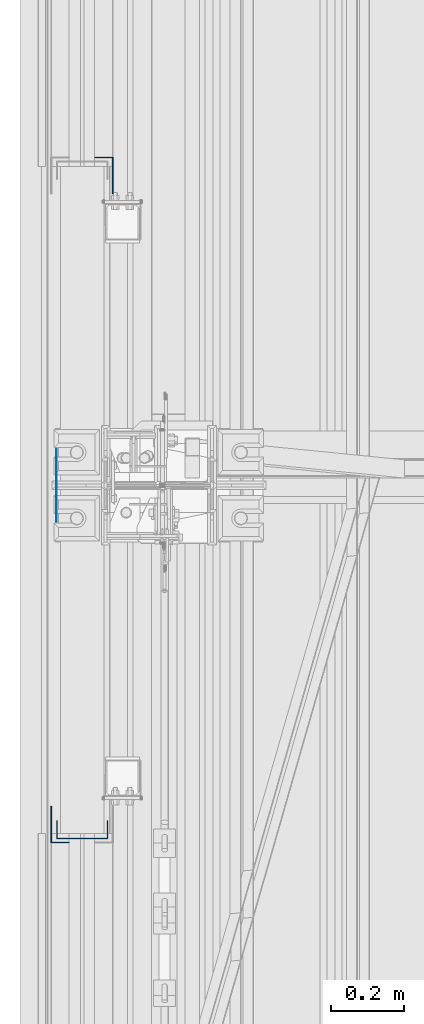
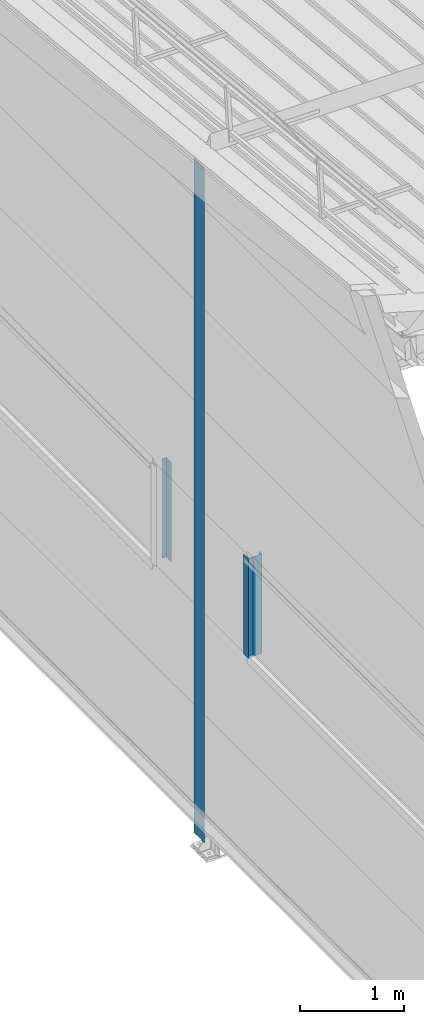
# One storey, part 7 of 709: 4 columns, 4 elements without a shape of their own.
"""IFC4 building model written with IfcOpenShell, lengths in millimetres."""

import ifcopenshell
import ifcopenshell.guid

model = None  # the IFC model being written
_history = None  # IfcOwnerHistory: only IFC2X3 demands one
_inside = {}  # id of a spatial element -> (the spatial element, [elements in it])
_under = {}  # id of a project, library or spatial element -> (it, [spatial elements below it])
_declared = {}  # id of a project -> (the project, [libraries it declares])
_typed = {}  # id of a type object -> (the type object, [elements of that type])
_made_of = {}  # id of a material, layer set ... -> (it, [elements and type objects made of it])


def new_model(schema):
    """Start an empty IFC model of exactly this schema.

    Asked for "IFC4X3", IfcOpenShell would pick the latest addendum, in which some entities
    have other attributes; the version numbers below select the first issue.
    IFC2X3 requires an IfcOwnerHistory on every rooted entity: one is made here for all.
    """
    global model, _history
    if schema == "IFC4X3":
        model = ifcopenshell.file(schema_version=(4, 3, 0, 0))
    else:
        model = ifcopenshell.file(schema=schema)
    _inside.clear()
    _under.clear()
    _declared.clear()
    _typed.clear()
    _made_of.clear()
    _history = None
    if model.schema == "IFC2X3":
        org = make("IfcOrganization", Name="unknown")
        user = make(
            "IfcPersonAndOrganization",
            ThePerson=make("IfcPerson", FamilyName="unknown"),
            TheOrganization=org,
        )
        app = make(
            "IfcApplication",
            ApplicationDeveloper=org,
            Version="unknown",
            ApplicationFullName="unknown",
            ApplicationIdentifier="unknown",
        )
        _history = make(
            "IfcOwnerHistory",
            OwningUser=user,
            OwningApplication=app,
            ChangeAction="ADDED",
            CreationDate=0,
        )
    return model


def make(cls, **values):
    """One entity of the class cls with the attributes given. An attribute that is None is left unset."""
    return model.create_entity(
        cls, **{name: value for name, value in values.items() if value is not None}
    )


def rooted(cls, **values):
    """An entity with a GlobalId (a new one), such as an element, a storey or a relation."""
    return make(cls, GlobalId=ifcopenshell.guid.new(), OwnerHistory=_history, **values)


def si_unit(unit_type, name, prefix=None):
    """IfcSIUnit, for example si_unit("LENGTHUNIT", "METRE", prefix="MILLI")."""
    return make("IfcSIUnit", UnitType=unit_type, Prefix=prefix, Name=name)


def assignment(units):
    """IfcUnitAssignment: the units of a project."""
    return None if units is None else make("IfcUnitAssignment", Units=units)


def point(xyz):
    """IfcCartesianPoint."""
    return None if xyz is None else make("IfcCartesianPoint", Coordinates=xyz)


def direction(xyz):
    """IfcDirection."""
    return None if xyz is None else make("IfcDirection", DirectionRatios=xyz)


def frame(location, z_axis=None, x_axis=None):
    """IfcAxis2Placement3D, a coordinate frame: its origin and axes. An axis left out is left unset."""
    return make(
        "IfcAxis2Placement3D",
        Location=point(location),
        Axis=direction(z_axis),
        RefDirection=direction(x_axis),
    )


def origin_with_axes():
    """The frame at (0, 0, 0) with the z axis (0, 0, 1) and the x axis (1, 0, 0) written out."""
    return frame((0.0, 0.0, 0.0), z_axis=(0.0, 0.0, 1.0), x_axis=(1.0, 0.0, 0.0))


def place(relative_to, where):
    """IfcLocalPlacement: puts the frame where relative to a parent placement (None: the world)."""
    return make(
        "IfcLocalPlacement", PlacementRelTo=relative_to, RelativePlacement=where
    )


def context(
    kind, dimensions, precision=None, world=None, true_north=None, identifier=None
):
    """IfcGeometricRepresentationContext, for example the 3D "Model" context."""
    return make(
        "IfcGeometricRepresentationContext",
        ContextIdentifier=identifier,
        ContextType=kind,
        CoordinateSpaceDimension=dimensions,
        Precision=precision,
        WorldCoordinateSystem=world,
        TrueNorth=true_north,
    )


def subcontext(parent, identifier, kind, view, scale=None):
    """IfcGeometricRepresentationSubContext, for example "Body" below "Model"."""
    return make(
        "IfcGeometricRepresentationSubContext",
        ContextIdentifier=identifier,
        ContextType=kind,
        ParentContext=parent,
        TargetScale=scale,
        TargetView=view,
    )


def project(units=None, contexts=None):
    """IfcProject with its units and contexts."""
    return rooted(
        "IfcProject",
        Name="project",
        RepresentationContexts=contexts,
        UnitsInContext=assignment(units),
    )


def spatial(cls, under=None, at=None, **own):
    """A site, building, storey or space (cls), placed at a placement, below another one or the project."""
    s = rooted(cls, ObjectPlacement=at, **own)
    if under is not None:
        _under.setdefault(under.id(), (under, []))[1].append(s)
    return s


def point_list(points):
    """IfcCartesianPointList2D or 3D."""
    cls = (
        "IfcCartesianPointList2D" if len(points[0]) == 2 else "IfcCartesianPointList3D"
    )
    return make(cls, CoordList=points)


def line(*indices):
    """IfcLineIndex: a straight run through numbered points of an indexed curve."""
    return model.create_entity("IfcLineIndex", indices)


def indexed_curve(points, segments=None, self_intersect=None):
    """IfcIndexedPolyCurve: lines and arcs through numbered points (the first is 1)."""
    return make(
        "IfcIndexedPolyCurve",
        Points=point_list(points),
        Segments=segments,
        SelfIntersect=self_intersect,
    )


def outline(outer, holes=None, kind="AREA"):
    """IfcArbitraryClosedProfileDef: a profile drawn as a closed curve; with holes, ...WithVoids."""
    if holes is None:
        return make("IfcArbitraryClosedProfileDef", ProfileType=kind, OuterCurve=outer)
    return make(
        "IfcArbitraryProfileDefWithVoids",
        ProfileType=kind,
        OuterCurve=outer,
        InnerCurves=holes,
    )


def extrude(swept, where, along, depth):
    """IfcExtrudedAreaSolid: the profile swept, set in the frame where, extruded along a direction by depth."""
    return make(
        "IfcExtrudedAreaSolid",
        SweptArea=swept,
        Position=where,
        ExtrudedDirection=direction(along),
        Depth=depth,
    )


def shape(context_of_items, identifier, shape_type, items):
    """IfcShapeRepresentation: the items that make up one representation, for example the "Body"."""
    return make(
        "IfcShapeRepresentation",
        ContextOfItems=context_of_items,
        RepresentationIdentifier=identifier,
        RepresentationType=shape_type,
        Items=items,
    )


def material(Name=None, Category=None):
    """IfcMaterial."""
    return make("IfcMaterial", Name=Name, Category=Category)


def made_of(thing, what):
    """Note that an element or type object is made of a material, layer set ...; save() writes the relation."""
    if what is not None:
        _made_of.setdefault(what.id(), (what, []))[1].append(thing)
    return thing


def element(
    cls,
    number,
    at=None,
    inside=None,
    cuts=None,
    type_object=None,
    material=None,
    context=None,
    identifier="Body",
    shape_type=None,
    held_by="IfcProductDefinitionShape",
    body=None,
    shapes=None,
    **own,
):
    """One element of the class cls, such as IfcWall. Its Tag is "e" and its number.

    at: its placement. inside: the storey or other place that contains it. cuts: it is an
    opening in that element (IfcRelVoidsElement). A single representation is given by context,
    identifier, shape_type and body (its items); several are given by shapes. held_by: the class
    of the entity that holds the representations. save() writes the other relations.
    """
    e = rooted(cls, Tag="e%d" % number, ObjectPlacement=at, **own)
    if body is not None:
        shapes = [shape(context, identifier, shape_type, body)]
    if shapes is not None:
        e.Representation = make(held_by, Representations=shapes)
    if inside is not None:
        _inside.setdefault(inside.id(), (inside, []))[1].append(e)
    if cuts is not None:
        rooted(
            "IfcRelVoidsElement", RelatingBuildingElement=cuts, RelatedOpeningElement=e
        )
    if type_object is not None:
        _typed.setdefault(type_object.id(), (type_object, []))[1].append(e)
    return made_of(e, material)


def aggregate(whole, parts):
    """IfcRelAggregates: a whole, such as a stair, and the parts it consists of."""
    return rooted("IfcRelAggregates", RelatingObject=whole, RelatedObjects=parts)


def save(model, path):
    """Write the relations noted so far, then the file.

    IfcRelAggregates (storeys below a building ...), IfcRelContainedInSpatialStructure (elements
    in a storey), IfcRelDefinesByType, IfcRelAssociatesMaterial and IfcRelDeclares: one each for
    every whole, place, type object, material and project.
    """
    for whole, parts in _under.values():
        aggregate(whole, parts)
    for where, things in _inside.values():
        rooted(
            "IfcRelContainedInSpatialStructure",
            RelatedElements=things,
            RelatingStructure=where,
        )
    for kind, things in _typed.values():
        rooted("IfcRelDefinesByType", RelatedObjects=things, RelatingType=kind)
    for what, things in _made_of.values():
        rooted("IfcRelAssociatesMaterial", RelatedObjects=things, RelatingMaterial=what)
    for by, libraries in _declared.values():
        rooted("IfcRelDeclares", RelatingContext=by, RelatedDefinitions=libraries)
    model.write(path)


model = new_model("IFC4")

# Units and contexts
model_context = context("Model", 3, precision=0.2, world=origin_with_axes(), true_north=direction((0.0, 1.0)))
body_context = subcontext(model_context, "Body", "Model", "MODEL_VIEW")
ifc_project = project(units=[si_unit("LENGTHUNIT", "METRE", prefix="MILLI"), si_unit("AREAUNIT", "SQUARE_METRE"), si_unit("VOLUMEUNIT", "CUBIC_METRE"), si_unit("MASSUNIT", "GRAM", prefix="KILO"), si_unit("TIMEUNIT", "SECOND"), si_unit("PLANEANGLEUNIT", "RADIAN"), si_unit("SOLIDANGLEUNIT", "STERADIAN"), si_unit("THERMODYNAMICTEMPERATUREUNIT", "DEGREE_CELSIUS"), si_unit("LUMINOUSINTENSITYUNIT", "LUMEN")], contexts=[model_context])

# Site, building, storey
site_placement = place(None, origin_with_axes())
site = spatial("IfcSite", under=ifc_project, at=site_placement, CompositionType="ELEMENT")
building_placement = place(site_placement, origin_with_axes())
building = spatial("IfcBuilding", under=site, at=building_placement, Name="Undefined", CompositionType="ELEMENT")
storey_placement = place(building_placement, origin_with_axes())
storey = spatial("IfcBuildingStorey", under=building, at=storey_placement, Name="Undefined", CompositionType="ELEMENT", Elevation=0.0)

# Assembly, column
assembly_1_placement = place(storey_placement, frame((-60.0, 15560.0, 2700.0), z_axis=(1.0, 0.0, 0.0), x_axis=(0.0, 0.0, 1.0)))
assembly_1 = element("IfcElementAssembly", 1, at=assembly_1_placement, inside=storey)
ifc_material = material(Name="Steel_Undefined", Category="STEEL")
column_1_placement = place(assembly_1_placement, origin_with_axes())
column_1 = element("IfcColumn", 2, at=column_1_placement, material=ifc_material, context=body_context, shape_type="SolidModel", body=[
    extrude(outline(indexed_curve([(-70.0, -25.0), (-68.0, -25.0), (-68.0, 23.0), (68.0, 23.0), (68.0, -25.0), (70.0, -25.0), (70.0, 25.0), (-70.0, 25.0)], segments=[line(1, 2, 3, 4, 5, 6, 7, 8, 1)])), frame((0.0, 0.0, 0.0), z_axis=(-1.0, 0.0, 0.0), x_axis=(0.0, 0.0, 1.0)), (0.0, 0.0, -1.0), 1170.0),
])
aggregate(assembly_1, [column_1])

assembly_2_placement = place(storey_placement, frame((-121.0, 15525.0, 2700.0), z_axis=(-1.0, 0.0, 0.0), x_axis=(0.0, 0.0, 1.0)))
assembly_2 = element("IfcElementAssembly", 3, at=assembly_2_placement, inside=storey)
column_2_placement = place(assembly_2_placement, origin_with_axes())
column_2 = element("IfcColumn", 4, at=column_2_placement, material=ifc_material, context=body_context, shape_type="SolidModel", body=[
    extrude(outline(indexed_curve([(-25.0, -1.0), (25.0, -1.0), (25.0, 99.0), (23.0, 99.0), (23.0, 1.0), (-25.0, 1.0)], segments=[line(1, 2, 3, 4, 5, 6, 1)])), frame((0.0, 0.0, 0.0), z_axis=(-1.0, 0.0, 0.0), x_axis=(0.0, 0.0, 1.0)), (0.0, 0.0, -1.0), 1170.0),
])
aggregate(assembly_2, [column_2])

assembly_3_placement = place(storey_placement, frame((-1.0, 17395.0, 2700.0), z_axis=(1.0, 0.0, 0.0), x_axis=(0.0, 0.0, 1.0)))
assembly_3 = element("IfcElementAssembly", 5, at=assembly_3_placement, inside=storey)
column_3_placement = place(assembly_3_placement, origin_with_axes())
column_3 = element("IfcColumn", 6, at=column_3_placement, material=ifc_material, context=body_context, shape_type="SolidModel", body=[
    extrude(outline(indexed_curve([(-25.0, -1.0), (25.0, -1.0), (25.0, 99.0), (23.0, 99.0), (23.0, 1.0), (-25.0, 1.0)], segments=[line(1, 2, 3, 4, 5, 6, 1)])), frame((0.0, 0.0, 0.0), z_axis=(-1.0, 0.0, 0.0), x_axis=(0.0, 0.0, 1.0)), (0.0, 0.0, -1.0), 1170.0),
])
aggregate(assembly_3, [column_3])

assembly_4_placement = place(storey_placement, frame((-130.0, 16500.0, 0.0), z_axis=(-1.0, 0.0, 0.0), x_axis=(0.0, 0.0, 1.0)))
assembly_4 = element("IfcElementAssembly", 7, at=assembly_4_placement, inside=storey)
column_4_placement = place(assembly_4_placement, origin_with_axes())
column_4 = element("IfcColumn", 8, at=column_4_placement, material=ifc_material, context=body_context, shape_type="SolidModel", body=[
    extrude(outline(indexed_curve([(-0.375, -100.0), (1.245, -100.0), (1.245, -50.0), (0.495, -50.0), (0.495, -99.25), (0.375, -99.25), (0.375, 99.25), (0.495, 99.25), (0.495, 50.0), (1.245, 50.0), (1.245, 100.0), (-0.375, 100.0)], segments=[line(1, 2, 3, 4, 5, 6, 7, 8, 9, 10, 11, 12, 1)])), frame((0.0, 0.0, 0.0), z_axis=(-1.0, 0.0, 0.0), x_axis=(0.0, 0.0, 1.0)), (0.0, 0.0, -1.0), 7929.67111),
])
aggregate(assembly_4, [column_4])

save(model, "model.ifc")
